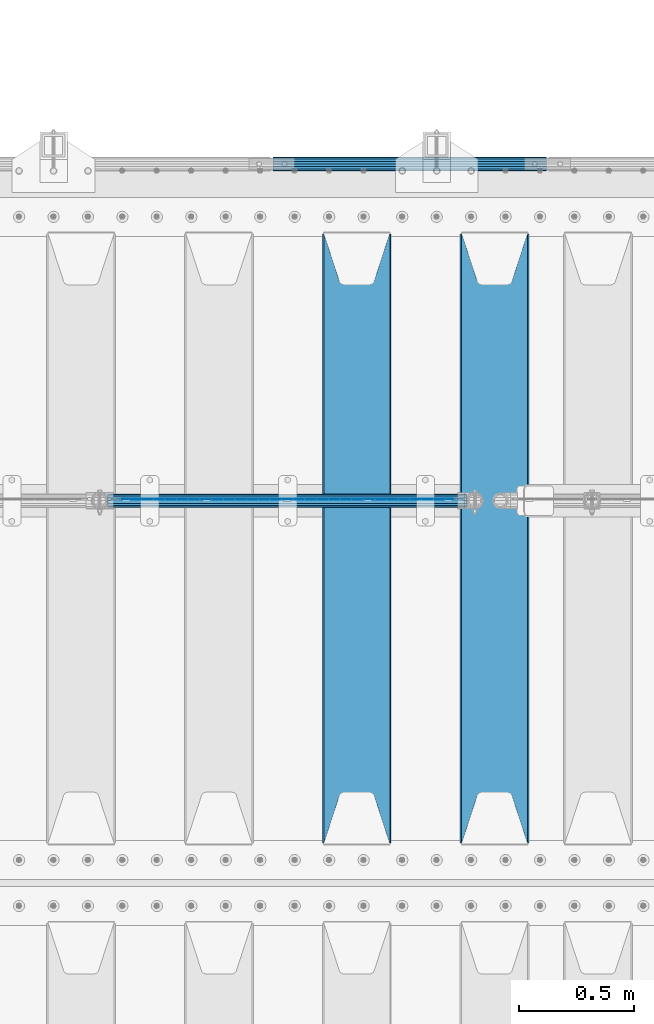
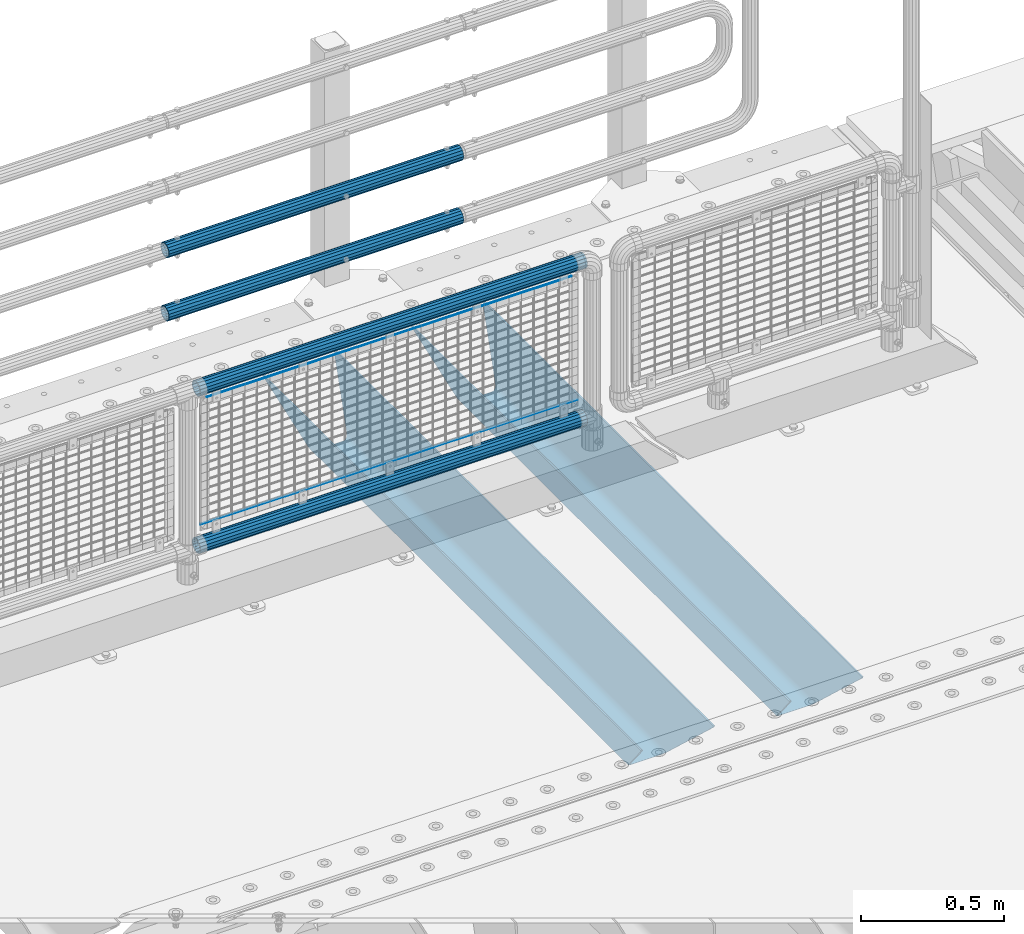
# One storey, part 147 of 270: 8 beams.
"""IFC2X3 building model written with IfcOpenShell, lengths in millimetres."""

from ifc_helpers import new_model, si_unit, frame, origin_with_axes, place, context, subcontext, project, spatial, faceted_brep, material, type_object, element, save


model = new_model("IFC2X3")

# Units and contexts
model_context = context("Model", 3, precision=1e-05, world=origin_with_axes())
body_context = subcontext(model_context, "Body", "Model", "MODEL_VIEW")
ifc_project = project(units=[si_unit("LENGTHUNIT", "METRE", prefix="MILLI"), si_unit("AREAUNIT", "SQUARE_METRE"), si_unit("VOLUMEUNIT", "CUBIC_METRE"), si_unit("MASSUNIT", "GRAM", prefix="KILO"), si_unit("TIMEUNIT", "SECOND"), si_unit("PLANEANGLEUNIT", "RADIAN"), si_unit("SOLIDANGLEUNIT", "STERADIAN"), si_unit("THERMODYNAMICTEMPERATUREUNIT", "DEGREE_CELSIUS"), si_unit("LUMINOUSINTENSITYUNIT", "LUMEN")], contexts=[model_context])

# Site, building, storey
site_placement = place(None, origin_with_axes())
site = spatial("IfcSite", under=ifc_project, at=site_placement, CompositionType="ELEMENT")
building_placement = place(site_placement, origin_with_axes())
building = spatial("IfcBuilding", under=site, at=building_placement, Name="Standard", CompositionType="ELEMENT")
storey_placement = place(building_placement, origin_with_axes())
storey = spatial("IfcBuildingStorey", under=building, at=storey_placement, Name="Undefined", CompositionType="ELEMENT", Elevation=0.0)

# Beams
ifc_material_1 = material()
beam_type_1 = type_object("IfcBeamType", PredefinedType="NOTDEFINED")
beam_1_placement = place(storey_placement, frame((17705.0000000001, -14870.1500000004, 419.849999999726), z_axis=(0.0, -1.0, 0.0), x_axis=(1.0, 0.0, 0.0)))
element("IfcBeam", 1, at=beam_1_placement, inside=storey, type_object=beam_type_1, material=ifc_material_1, context=body_context, shape_type="Brep", body=[
    faceted_brep([(0.0, -26.5499999999993, 0.0), (0.0, -24.5290015881747, 10.1602451292931), (1190.0, -24.5290015881747, 10.1602451292929), (1190.0, -26.55, 0.0), (0.0, -18.7736850405036, 18.7736850405028), (1190.0, -18.7736850405028, 18.7736850405036), (0.0, -10.1602451292929, 24.5290015881747), (1190.0, -10.1602451292931, 24.5290015881747), (0.0, 0.0, 26.55), (1190.0, 0.0, 26.5499999999993), (0.0, 10.1602451292929, 24.5290015881747), (1190.0, 10.1602451292932, 24.5290015881747), (0.0, 18.7736850405036, 18.7736850405028), (1190.0, 18.7736850405029, 18.7736850405036), (0.0, 24.5290015881747, 10.1602451292931), (1190.0, 24.5290015881747, 10.1602451292929), (0.0, 26.5499999999993, 0.0), (1190.0, 26.55, 0.0), (0.0, 24.5290015881747, -10.1602451292931), (1190.0, 24.5290015881747, -10.1602451292929), (0.0, 18.7736850405036, -18.7736850405028), (1190.0, 18.7736850405028, -18.7736850405036), (0.0, 10.1602451292929, -24.5290015881747), (1190.0, 10.1602451292931, -24.5290015881747), (0.0, 0.0, -26.55), (1190.0, 0.0, -26.5499999999993), (0.0, -10.1602451292929, -24.5290015881747), (1190.0, -10.1602451292931, -24.5290015881747), (0.0, -18.7736850405036, -18.7736850405028), (1190.0, -18.7736850405028, -18.7736850405036), (0.0, -24.5290015881747, -10.1602451292931), (1190.0, -24.5290015881747, -10.1602451292929), (0.0, -30.1499999999996, 0.0), (0.0, -27.8549679052157, -11.5379054858058), (1190.0, -27.8549679052153, -11.5379054858076), (1190.0, -30.15, 0.0), (0.0, -21.3192694527752, -21.3192694527752), (1190.0, -21.3192694527744, -21.3192694527752), (0.0, -11.5379054858076, -27.8549679052157), (1190.0, -11.5379054858075, -27.8549679052157), (0.0, 0.0, -30.1500000000015), (1190.0, 0.0, -30.1499999999996), (0.0, 11.5379054858076, -27.8549679052157), (1190.0, 11.5379054858075, -27.8549679052157), (0.0, 21.3192694527752, -21.3192694527752), (1190.0, 21.3192694527744, -21.3192694527752), (0.0, 27.8549679052157, -11.5379054858058), (1190.0, 27.8549679052153, -11.5379054858076), (0.0, 30.1499999999996, 0.0), (1190.0, 30.15, 0.0), (0.0, 27.8549679052157, 11.5379054858058), (1190.0, 27.8549679052153, 11.5379054858076), (0.0, 21.3192694527752, 21.3192694527752), (1190.0, 21.3192694527744, 21.3192694527752), (0.0, 11.5379054858076, 27.8549679052157), (1190.0, 11.5379054858075, 27.8549679052157), (0.0, 0.0, 30.1500000000015), (1190.0, 0.0, 30.1499999999996), (0.0, -11.5379054858076, 27.8549679052157), (1190.0, -11.5379054858075, 27.8549679052157), (0.0, -21.3192694527752, 21.3192694527752), (1190.0, -21.3192694527744, 21.3192694527752), (0.0, -27.8549679052157, 11.5379054858058), (1190.0, -27.8549679052153, 11.5379054858076)], [[[0, 1, 2, 3]], [[1, 4, 5, 2]], [[4, 6, 7, 5]], [[6, 8, 9, 7]], [[8, 10, 11, 9]], [[10, 12, 13, 11]], [[12, 14, 15, 13]], [[14, 16, 17, 15]], [[16, 18, 19, 17]], [[18, 20, 21, 19]], [[20, 22, 23, 21]], [[22, 24, 25, 23]], [[24, 26, 27, 25]], [[26, 28, 29, 27]], [[28, 30, 31, 29]], [[30, 0, 3, 31]], [[32, 33, 34, 35]], [[33, 36, 37, 34]], [[36, 38, 39, 37]], [[38, 40, 41, 39]], [[40, 42, 43, 41]], [[42, 44, 45, 43]], [[44, 46, 47, 45]], [[46, 48, 49, 47]], [[48, 50, 51, 49]], [[50, 52, 53, 51]], [[52, 54, 55, 53]], [[54, 56, 57, 55]], [[56, 58, 59, 57]], [[58, 60, 61, 59]], [[60, 62, 63, 61]], [[62, 32, 35, 63]], [[37, 39, 41, 43, 45, 47, 49, 51, 53, 55, 57, 59, 61, 63, 35, 34], [5, 7, 9, 11, 13, 15, 17, 19, 21, 23, 25, 27, 29, 31, 3, 2]], [[62, 60, 58, 56, 54, 52, 50, 48, 46, 44, 42, 40, 38, 36, 33, 32], [30, 28, 26, 24, 22, 20, 18, 16, 14, 12, 10, 8, 6, 4, 1, 0]]]),
])
beam_2_placement = place(storey_placement, frame((17705.0000000001, -14870.1500000004, 149.549999999726), z_axis=(0.0, -1.0, 0.0), x_axis=(1.0, 0.0, 0.0)))
element("IfcBeam", 2, at=beam_2_placement, inside=storey, type_object=beam_type_1, material=ifc_material_1, context=body_context, shape_type="Brep", body=[
    faceted_brep([(0.0, -26.5499999999993, 0.0), (0.0, -24.5290015881747, 10.1602451292931), (1190.0, -24.5290015881747, 10.1602451292929), (1190.0, -26.55, 0.0), (0.0, -18.7736850405036, 18.7736850405028), (1190.0, -18.7736850405028, 18.7736850405036), (0.0, -10.1602451292929, 24.5290015881747), (1190.0, -10.1602451292931, 24.5290015881747), (0.0, 0.0, 26.55), (1190.0, 0.0, 26.5499999999993), (0.0, 10.1602451292929, 24.5290015881747), (1190.0, 10.1602451292932, 24.5290015881747), (0.0, 18.7736850405036, 18.7736850405028), (1190.0, 18.7736850405029, 18.7736850405036), (0.0, 24.5290015881747, 10.1602451292931), (1190.0, 24.5290015881747, 10.1602451292929), (0.0, 26.5499999999993, 0.0), (1190.0, 26.55, 0.0), (0.0, 24.5290015881747, -10.1602451292931), (1190.0, 24.5290015881747, -10.1602451292929), (0.0, 18.7736850405036, -18.7736850405028), (1190.0, 18.7736850405028, -18.7736850405036), (0.0, 10.1602451292929, -24.5290015881747), (1190.0, 10.1602451292931, -24.5290015881747), (0.0, 0.0, -26.55), (1190.0, 0.0, -26.5499999999993), (0.0, -10.1602451292929, -24.5290015881747), (1190.0, -10.1602451292931, -24.5290015881747), (0.0, -18.7736850405036, -18.7736850405028), (1190.0, -18.7736850405028, -18.7736850405036), (0.0, -24.5290015881747, -10.1602451292931), (1190.0, -24.5290015881747, -10.1602451292929), (0.0, -30.1499999999996, 0.0), (0.0, -27.8549679052157, -11.5379054858058), (1190.0, -27.8549679052153, -11.5379054858076), (1190.0, -30.15, 0.0), (0.0, -21.3192694527752, -21.3192694527752), (1190.0, -21.3192694527744, -21.3192694527752), (0.0, -11.5379054858076, -27.8549679052157), (1190.0, -11.5379054858075, -27.8549679052157), (0.0, 0.0, -30.1500000000015), (1190.0, 0.0, -30.1499999999996), (0.0, 11.5379054858076, -27.8549679052157), (1190.0, 11.5379054858075, -27.8549679052157), (0.0, 21.3192694527752, -21.3192694527752), (1190.0, 21.3192694527744, -21.3192694527752), (0.0, 27.8549679052157, -11.5379054858058), (1190.0, 27.8549679052153, -11.5379054858076), (0.0, 30.1499999999996, 0.0), (1190.0, 30.15, 0.0), (0.0, 27.8549679052157, 11.5379054858058), (1190.0, 27.8549679052153, 11.5379054858076), (0.0, 21.3192694527752, 21.3192694527752), (1190.0, 21.3192694527744, 21.3192694527752), (0.0, 11.5379054858076, 27.8549679052157), (1190.0, 11.5379054858075, 27.8549679052157), (0.0, 0.0, 30.1500000000015), (1190.0, 0.0, 30.1499999999996), (0.0, -11.5379054858076, 27.8549679052157), (1190.0, -11.5379054858075, 27.8549679052157), (0.0, -21.3192694527752, 21.3192694527752), (1190.0, -21.3192694527744, 21.3192694527752), (0.0, -27.8549679052157, 11.5379054858058), (1190.0, -27.8549679052153, 11.5379054858076)], [[[0, 1, 2, 3]], [[1, 4, 5, 2]], [[4, 6, 7, 5]], [[6, 8, 9, 7]], [[8, 10, 11, 9]], [[10, 12, 13, 11]], [[12, 14, 15, 13]], [[14, 16, 17, 15]], [[16, 18, 19, 17]], [[18, 20, 21, 19]], [[20, 22, 23, 21]], [[22, 24, 25, 23]], [[24, 26, 27, 25]], [[26, 28, 29, 27]], [[28, 30, 31, 29]], [[30, 0, 3, 31]], [[32, 33, 34, 35]], [[33, 36, 37, 34]], [[36, 38, 39, 37]], [[38, 40, 41, 39]], [[40, 42, 43, 41]], [[42, 44, 45, 43]], [[44, 46, 47, 45]], [[46, 48, 49, 47]], [[48, 50, 51, 49]], [[50, 52, 53, 51]], [[52, 54, 55, 53]], [[54, 56, 57, 55]], [[56, 58, 59, 57]], [[58, 60, 61, 59]], [[60, 62, 63, 61]], [[62, 32, 35, 63]], [[37, 39, 41, 43, 45, 47, 49, 51, 53, 55, 57, 59, 61, 63, 35, 34], [5, 7, 9, 11, 13, 15, 17, 19, 21, 23, 25, 27, 29, 31, 3, 2]], [[62, 60, 58, 56, 54, 52, 50, 48, 46, 44, 42, 40, 38, 36, 33, 32], [30, 28, 26, 24, 22, 20, 18, 16, 14, 12, 10, 8, 6, 4, 1, 0]]]),
])
ifc_material_2 = material(Name="STEEL/S355N")
beam_type_2 = type_object("IfcBeamType", PredefinedType="NOTDEFINED")
beam_3_placement = place(storey_placement, frame((18670.0, -17825.0, -115.0), z_axis=(0.0, 0.0, 1.0), x_axis=(0.0, 1.0, 0.0)))
element("IfcBeam", 3, at=beam_3_placement, inside=storey, type_object=beam_type_2, material=ifc_material_2, context=body_context, shape_type="Brep", body=[
    faceted_brep([(0.0, 150.0, 115.0), (0.0, 143.689999999999, 115.0), (2650.00000000297, 143.689999999999, 115.0), (2650.00000000297, 150.0, 115.0), (2650.00000000297, 142.059565218398, 110.000000003096), (2650.00000000297, 148.3695652184, 110.000000003096), (2441.90079219209, -80.1103600731112, -98.0992078077845), (2437.7588105432, -77.5672621345584, -102.241189456673), (2434.06523489747, -74.4080125315522, -105.934765102404), (2430.9108609509, -70.710272125576, -109.089139048974), (2428.37322971128, -66.5649389910068, -111.626770288588), (2426.51472138055, -62.0739139532889, -113.485278619323), (2425.38102192092, -57.3475956567672, -114.618978078955), (2424.99999999987, -52.5021667386536, -115.0), (2424.99999999987, 52.5021667386536, -115.0), (2425.38102192092, 57.3475956567672, -114.618978078955), (2426.51472138055, 62.0739139532889, -113.485278619323), (2428.37322971128, 66.5649389910068, -111.626770288588), (2430.9108609509, 70.710272125576, -109.089139048974), (2434.06523489747, 74.4080125315522, -105.934765102404), (2437.7588105432, 77.5672621345584, -102.241189456673), (2441.90079219209, 80.1103600731112, -98.0992078077846), (2446.38936140511, 81.9747917625791, -93.6106385947584), (2448.2494850041, 76.2713538057251, -91.7505149957729), (2444.62967112263, 74.76777986261, -95.3703288772456), (2441.28936334126, 72.7168944282894, -98.710636658607), (2438.31067330439, 70.1691124903846, -101.689326695487), (2435.76682334747, 67.1870637758839, -104.233176652398), (2433.72034654133, 63.8440531834895, -106.279653458539), (2432.22154950042, 60.222258798236, -107.778450499454), (2431.30727574265, 56.4107117849089, -108.692724257221), (2430.99999999987, 52.5031078186876, -109.0), (2430.99999999987, -52.5031078186876, -109.0), (2431.30727574265, -56.4107117849089, -108.692724257221), (2432.22154950042, -60.222258798236, -107.778450499454), (2433.72034654133, -63.8440531834895, -106.279653458539), (2435.76682334747, -67.1870637758839, -104.233176652398), (2438.31067330438, -70.1691124903846, -101.689326695487), (2441.28936334126, -72.7168944282894, -98.7106366586071), (2444.62967112263, -74.76777986261, -95.3703288772457), (2448.2494850041, -76.2713538057251, -91.7505149957729), (2650.00000000297, -142.059565218398, 110.000000003096), (2650.00000000297, -148.3695652184, 110.000000003096), (2446.38936140511, -81.9747917625791, -93.6106385947584), (2650.00000000297, -143.689999999999, 115.0), (2650.00000000297, -150.0, 115.0), (0.0, -143.689999999999, 115.0), (0.0, -150.0, 115.0), (0.0, -148.369565218261, 110.000000002672), (203.610638597431, -81.9747917625791, -93.6106385947584), (208.099207810457, -80.1103600731112, -98.0992078077845), (212.241189459342, -77.5672621345584, -102.241189456673), (215.934765105078, -74.4080125315522, -105.934765102404), (219.089139051644, -70.710272125576, -109.089139048974), (221.626770291259, -66.5649389910068, -111.626770288588), (223.485278621993, -62.0739139532889, -113.485278619323), (224.618978081628, -57.3475956567672, -114.618978078955), (225.00000000267, -52.5021667386536, -115.0), (225.00000000267, 52.5021667386536, -115.0), (224.618978081628, 57.3475956567672, -114.618978078955), (223.485278621993, 62.0739139532889, -113.485278619323), (221.626770291259, 66.5649389910068, -111.626770288588), (219.089139051644, 70.710272125576, -109.089139048974), (215.934765105078, 74.4080125315522, -105.934765102404), (212.241189459342, 77.5672621345584, -102.241189456673), (208.099207810457, 80.1103600731112, -98.0992078077846), (203.610638597431, 81.9747917625791, -93.6106385947584), (0.0, 148.369565218261, 110.000000002672), (0.0, 142.05956521826, 110.000000002672), (201.750514998446, 76.2713538057251, -91.7505149957729), (205.370328879915, 74.76777986261, -95.3703288772456), (208.710636661279, 72.7168944282894, -98.710636658607), (211.689326698157, 70.1691124903846, -101.689326695487), (214.233176655071, 67.1870637758839, -104.233176652398), (216.27965346121, 63.8440531834895, -106.279653458539), (217.778450502126, 60.222258798236, -107.778450499454), (218.692724259894, 56.4107117849089, -108.692724257221), (219.00000000267, 52.5031078186876, -109.0), (219.00000000267, -52.5031078186876, -109.0), (218.692724259894, -56.4107117849089, -108.692724257221), (217.778450502123, -60.222258798236, -107.778450499454), (216.27965346121, -63.8440531834895, -106.279653458539), (214.233176655071, -67.1870637758839, -104.233176652398), (211.689326698157, -70.1691124903846, -101.689326695487), (208.710636661279, -72.7168944282894, -98.7106366586071), (205.370328879915, -74.76777986261, -95.3703288772457), (201.750514998446, -76.2713538057251, -91.7505149957729), (0.0, -142.05956521826, 110.000000002672)], [[[0, 1, 2, 3]], [[3, 2, 4, 5]], [[6, 7, 8, 9, 10, 11, 12, 13, 14, 15, 16, 17, 18, 19, 20, 21, 22, 5, 4, 23, 24, 25, 26, 27, 28, 29, 30, 31, 32, 33, 34, 35, 36, 37, 38, 39, 40, 41, 42, 43]], [[44, 45, 42, 41]], [[46, 47, 45, 44]], [[43, 42, 45, 47, 48, 49]], [[6, 43, 49, 50]], [[7, 6, 50, 51]], [[8, 7, 51, 52]], [[9, 8, 52, 53]], [[10, 9, 53, 54]], [[11, 10, 54, 55]], [[12, 11, 55, 56]], [[13, 12, 56, 57]], [[14, 13, 57, 58]], [[15, 14, 58, 59]], [[16, 15, 59, 60]], [[17, 16, 60, 61]], [[18, 17, 61, 62]], [[19, 18, 62, 63]], [[20, 19, 63, 64]], [[21, 20, 64, 65]], [[22, 21, 65, 66]], [[0, 3, 5, 22, 66, 67]], [[1, 0, 67, 68]], [[23, 4, 2, 1, 68, 69]], [[24, 23, 69, 70]], [[25, 24, 70, 71]], [[26, 25, 71, 72]], [[27, 26, 72, 73]], [[28, 27, 73, 74]], [[29, 28, 74, 75]], [[30, 29, 75, 76]], [[31, 30, 76, 77]], [[32, 31, 77, 78]], [[33, 32, 78, 79]], [[34, 33, 79, 80]], [[35, 34, 80, 81]], [[36, 35, 81, 82]], [[37, 36, 82, 83]], [[38, 37, 83, 84]], [[39, 38, 84, 85]], [[40, 39, 85, 86]], [[46, 44, 41, 40, 86, 87]], [[47, 46, 87, 48]], [[86, 85, 84, 83, 82, 81, 80, 79, 78, 77, 76, 75, 74, 73, 72, 71, 70, 69, 68, 67, 66, 65, 64, 63, 62, 61, 60, 59, 58, 57, 56, 55, 54, 53, 52, 51, 50, 49, 48, 87]]]),
])
beam_4_placement = place(storey_placement, frame((18070.0, -17825.0, -115.0), z_axis=(0.0, 0.0, 1.0), x_axis=(0.0, 1.0, 0.0)))
element("IfcBeam", 4, at=beam_4_placement, inside=storey, type_object=beam_type_2, material=ifc_material_2, context=body_context, shape_type="Brep", body=[
    faceted_brep([(0.0, 150.0, 115.0), (0.0, 143.689999999999, 115.0), (2650.00000000297, 143.689999999999, 115.0), (2650.00000000297, 150.0, 115.0), (2650.00000000297, 142.059565218398, 110.000000003096), (2650.00000000297, 148.3695652184, 110.000000003096), (2441.90079219209, -80.1103600731112, -98.0992078077845), (2437.7588105432, -77.5672621345584, -102.241189456673), (2434.06523489747, -74.4080125315522, -105.934765102404), (2430.9108609509, -70.710272125576, -109.089139048974), (2428.37322971128, -66.5649389910068, -111.626770288588), (2426.51472138055, -62.0739139532889, -113.485278619323), (2425.38102192092, -57.3475956567672, -114.618978078955), (2424.99999999987, -52.5021667386536, -115.0), (2424.99999999987, 52.5021667386536, -115.0), (2425.38102192092, 57.3475956567672, -114.618978078955), (2426.51472138055, 62.0739139532889, -113.485278619323), (2428.37322971128, 66.5649389910068, -111.626770288588), (2430.9108609509, 70.710272125576, -109.089139048974), (2434.06523489747, 74.4080125315522, -105.934765102404), (2437.7588105432, 77.5672621345584, -102.241189456673), (2441.90079219209, 80.1103600731112, -98.0992078077846), (2446.38936140511, 81.9747917625791, -93.6106385947584), (2448.2494850041, 76.2713538057251, -91.7505149957729), (2444.62967112263, 74.76777986261, -95.3703288772456), (2441.28936334126, 72.7168944282894, -98.710636658607), (2438.31067330439, 70.1691124903846, -101.689326695487), (2435.76682334747, 67.1870637758839, -104.233176652398), (2433.72034654133, 63.8440531834895, -106.279653458539), (2432.22154950042, 60.222258798236, -107.778450499454), (2431.30727574265, 56.4107117849089, -108.692724257221), (2430.99999999987, 52.5031078186876, -109.0), (2430.99999999987, -52.5031078186876, -109.0), (2431.30727574265, -56.4107117849089, -108.692724257221), (2432.22154950042, -60.222258798236, -107.778450499454), (2433.72034654133, -63.8440531834895, -106.279653458539), (2435.76682334747, -67.1870637758839, -104.233176652398), (2438.31067330438, -70.1691124903846, -101.689326695487), (2441.28936334126, -72.7168944282894, -98.7106366586071), (2444.62967112263, -74.76777986261, -95.3703288772457), (2448.2494850041, -76.2713538057251, -91.7505149957729), (2650.00000000297, -142.059565218398, 110.000000003096), (2650.00000000297, -148.3695652184, 110.000000003096), (2446.38936140511, -81.9747917625791, -93.6106385947584), (2650.00000000297, -143.689999999999, 115.0), (2650.00000000297, -150.0, 115.0), (0.0, -143.689999999999, 115.0), (0.0, -150.0, 115.0), (0.0, -148.369565218261, 110.000000002672), (203.610638597431, -81.9747917625791, -93.6106385947584), (208.099207810457, -80.1103600731112, -98.0992078077845), (212.241189459342, -77.5672621345584, -102.241189456673), (215.934765105078, -74.4080125315522, -105.934765102404), (219.089139051644, -70.710272125576, -109.089139048974), (221.626770291259, -66.5649389910068, -111.626770288588), (223.485278621993, -62.0739139532889, -113.485278619323), (224.618978081628, -57.3475956567672, -114.618978078955), (225.00000000267, -52.5021667386536, -115.0), (225.00000000267, 52.5021667386536, -115.0), (224.618978081628, 57.3475956567672, -114.618978078955), (223.485278621993, 62.0739139532889, -113.485278619323), (221.626770291259, 66.5649389910068, -111.626770288588), (219.089139051644, 70.710272125576, -109.089139048974), (215.934765105078, 74.4080125315522, -105.934765102404), (212.241189459342, 77.5672621345584, -102.241189456673), (208.099207810457, 80.1103600731112, -98.0992078077846), (203.610638597431, 81.9747917625791, -93.6106385947584), (0.0, 148.369565218261, 110.000000002672), (0.0, 142.05956521826, 110.000000002672), (201.750514998446, 76.2713538057251, -91.7505149957729), (205.370328879915, 74.76777986261, -95.3703288772456), (208.710636661279, 72.7168944282894, -98.710636658607), (211.689326698157, 70.1691124903846, -101.689326695487), (214.233176655071, 67.1870637758839, -104.233176652398), (216.27965346121, 63.8440531834895, -106.279653458539), (217.778450502126, 60.222258798236, -107.778450499454), (218.692724259894, 56.4107117849089, -108.692724257221), (219.00000000267, 52.5031078186876, -109.0), (219.00000000267, -52.5031078186876, -109.0), (218.692724259894, -56.4107117849089, -108.692724257221), (217.778450502123, -60.222258798236, -107.778450499454), (216.27965346121, -63.8440531834895, -106.279653458539), (214.233176655071, -67.1870637758839, -104.233176652398), (211.689326698157, -70.1691124903846, -101.689326695487), (208.710636661279, -72.7168944282894, -98.7106366586071), (205.370328879915, -74.76777986261, -95.3703288772457), (201.750514998446, -76.2713538057251, -91.7505149957729), (0.0, -142.05956521826, 110.000000002672)], [[[0, 1, 2, 3]], [[3, 2, 4, 5]], [[6, 7, 8, 9, 10, 11, 12, 13, 14, 15, 16, 17, 18, 19, 20, 21, 22, 5, 4, 23, 24, 25, 26, 27, 28, 29, 30, 31, 32, 33, 34, 35, 36, 37, 38, 39, 40, 41, 42, 43]], [[44, 45, 42, 41]], [[46, 47, 45, 44]], [[43, 42, 45, 47, 48, 49]], [[6, 43, 49, 50]], [[7, 6, 50, 51]], [[8, 7, 51, 52]], [[9, 8, 52, 53]], [[10, 9, 53, 54]], [[11, 10, 54, 55]], [[12, 11, 55, 56]], [[13, 12, 56, 57]], [[14, 13, 57, 58]], [[15, 14, 58, 59]], [[16, 15, 59, 60]], [[17, 16, 60, 61]], [[18, 17, 61, 62]], [[19, 18, 62, 63]], [[20, 19, 63, 64]], [[21, 20, 64, 65]], [[22, 21, 65, 66]], [[0, 3, 5, 22, 66, 67]], [[1, 0, 67, 68]], [[23, 4, 2, 1, 68, 69]], [[24, 23, 69, 70]], [[25, 24, 70, 71]], [[26, 25, 71, 72]], [[27, 26, 72, 73]], [[28, 27, 73, 74]], [[29, 28, 74, 75]], [[30, 29, 75, 76]], [[31, 30, 76, 77]], [[32, 31, 77, 78]], [[33, 32, 78, 79]], [[34, 33, 79, 80]], [[35, 34, 80, 81]], [[36, 35, 81, 82]], [[37, 36, 82, 83]], [[38, 37, 83, 84]], [[39, 38, 84, 85]], [[40, 39, 85, 86]], [[46, 44, 41, 40, 86, 87]], [[47, 46, 87, 48]], [[86, 85, 84, 83, 82, 81, 80, 79, 78, 77, 76, 75, 74, 73, 72, 71, 70, 69, 68, 67, 66, 65, 64, 63, 62, 61, 60, 59, 58, 57, 56, 55, 54, 53, 52, 51, 50, 49, 48, 87]]]),
])
ifc_material_3 = material(Name="Misc_Undefined")
beam_type_3 = type_object("IfcBeamType", Name="D3", PredefinedType="NOTDEFINED")
beam_5_placement = place(storey_placement, frame((17006.0, -16329.5, 378.02), z_axis=(0.0, 0.0, 1.0), x_axis=(1.0, 0.0, 0.0)))
element("IfcBeam", 5, at=beam_5_placement, inside=storey, type_object=beam_type_3, material=ifc_material_3, ObjectType="D3", context=body_context, shape_type="Brep", body=[
    faceted_brep([(0.0, -1.5, 0.0), (0.0, -0.75, -1.29903810567669), (1523.0, -0.75, -1.29903810567669), (1523.0, -1.5, 0.0), (0.0, 0.75, -1.29903810567669), (1523.0, 0.75, -1.29903810567669), (0.0, 1.5, 0.0), (1523.0, 1.5, 0.0), (0.0, 0.75, 1.29903810567669), (1523.0, 0.75, 1.29903810567669), (0.0, -0.75, 1.29903810567669), (1523.0, -0.75, 1.29903810567669)], [[[0, 1, 2, 3]], [[1, 4, 5, 2]], [[4, 6, 7, 5]], [[6, 8, 9, 7]], [[8, 10, 11, 9]], [[10, 0, 3, 11]], [[5, 7, 9, 11, 3, 2]], [[10, 8, 6, 4, 1, 0]]]),
])
beam_6_placement = place(storey_placement, frame((17031.0, -16329.5, 913.02), z_axis=(0.0, 0.0, 1.0), x_axis=(1.0, 0.0, 0.0)))
element("IfcBeam", 6, at=beam_6_placement, inside=storey, type_object=beam_type_3, material=ifc_material_3, ObjectType="D3", context=body_context, shape_type="Brep", body=[
    faceted_brep([(0.0, -1.5, 0.0), (0.0, -0.75, -1.29903810567669), (1473.0, -0.75, -1.29903810567669), (1473.0, -1.5, 0.0), (0.0, 0.75, -1.29903810567669), (1473.0, 0.75, -1.29903810567663), (0.0, 1.5, 0.0), (1473.0, 1.5, 0.0), (0.0, 0.75, 1.29903810567669), (1473.0, 0.75, 1.29903810567669), (0.0, -0.75, 1.29903810567669), (1473.0, -0.75, 1.29903810567669)], [[[0, 1, 2, 3]], [[1, 4, 5, 2]], [[4, 6, 7, 5]], [[6, 8, 9, 7]], [[8, 10, 11, 9]], [[10, 0, 3, 11]], [[5, 7, 9, 11, 3, 2]], [[10, 8, 6, 4, 1, 0]]]),
])
beam_type_4 = type_object("IfcBeamType", PredefinedType="NOTDEFINED")
beam_7_placement = place(storey_placement, frame((16985.85, -16335.5, 969.849999999999), z_axis=(0.0, 0.0, 1.0), x_axis=(1.0, 0.0, 0.0)))
element("IfcBeam", 7, at=beam_7_placement, inside=storey, type_object=beam_type_4, material=ifc_material_1, context=body_context, shape_type="Brep", body=[
    faceted_brep([(0.0, -25.3500000000004, 0.0), (0.0, -23.4203461491616, 9.70102501045403), (1563.0, -23.4203461491616, 9.70102501045506), (1563.0, -25.3500000000004, 0.0), (0.0, -17.9251569030785, 17.9251569030785), (1563.0, -17.9251569030785, 17.925156903079), (0.0, -9.70102501045585, 23.4203461491597), (1563.0, -9.70102501045585, 23.4203461491611), (0.0, 0.0, 25.3499999999985), (1563.0, 0.0, 25.35), (0.0, 9.70102501045585, 23.4203461491597), (1563.0, 9.70102501045585, 23.4203461491611), (0.0, 17.9251569030785, 17.9251569030785), (1563.0, 17.9251569030785, 17.925156903079), (0.0, 23.4203461491616, 9.70102501045403), (1563.0, 23.4203461491616, 9.70102501045506), (0.0, 25.3500000000004, 0.0), (1563.0, 25.3500000000004, 0.0), (0.0, 23.4203461491616, -9.70102501045403), (1563.0, 23.4203461491616, -9.70102501045506), (0.0, 17.9251569030785, -17.9251569030785), (1563.0, 17.9251569030785, -17.925156903079), (0.0, 9.70102501045585, -23.4203461491597), (1563.0, 9.70102501045585, -23.4203461491611), (0.0, 0.0, -25.3499999999985), (1563.0, 0.0, -25.35), (0.0, -9.70102501045585, -23.4203461491597), (1563.0, -9.70102501045585, -23.4203461491611), (0.0, -17.9251569030785, -17.9251569030785), (1563.0, -17.9251569030785, -17.925156903079), (0.0, -23.4203461491616, -9.70102501045403), (1563.0, -23.4203461491616, -9.70102501045506), (0.0, -30.1499999999996, 0.0), (0.0, -27.8549679052157, -11.5379054858058), (1563.0, -27.8549679052157, -11.5379054858075), (1563.0, -30.1499999999996, 0.0), (0.0, -21.3192694527752, -21.3192694527752), (1563.0, -21.3192694527752, -21.3192694527744), (0.0, -11.5379054858076, -27.8549679052157), (1563.0, -11.5379054858076, -27.8549679052153), (0.0, 0.0, -30.1500000000015), (1563.0, 0.0, -30.15), (0.0, 11.5379054858076, -27.8549679052157), (1563.0, 11.5379054858076, -27.8549679052153), (0.0, 21.3192694527752, -21.3192694527752), (1563.0, 21.3192694527752, -21.3192694527744), (0.0, 27.8549679052157, -11.5379054858058), (1563.0, 27.8549679052157, -11.5379054858074), (0.0, 30.1499999999996, 0.0), (1563.0, 30.1499999999996, 0.0), (0.0, 27.8549679052157, 11.5379054858058), (1563.0, 27.8549679052157, 11.5379054858074), (0.0, 21.3192694527752, 21.3192694527752), (1563.0, 21.3192694527752, 21.3192694527744), (0.0, 11.5379054858076, 27.8549679052157), (1563.0, 11.5379054858076, 27.8549679052153), (0.0, 0.0, 30.1500000000015), (1563.0, 0.0, 30.15), (0.0, -11.5379054858076, 27.8549679052157), (1563.0, -11.5379054858076, 27.8549679052153), (0.0, -21.3192694527752, 21.3192694527752), (1563.0, -21.3192694527752, 21.3192694527744), (0.0, -27.8549679052157, 11.5379054858058), (1563.0, -27.8549679052157, 11.5379054858074)], [[[0, 1, 2, 3]], [[1, 4, 5, 2]], [[4, 6, 7, 5]], [[6, 8, 9, 7]], [[8, 10, 11, 9]], [[10, 12, 13, 11]], [[12, 14, 15, 13]], [[14, 16, 17, 15]], [[16, 18, 19, 17]], [[18, 20, 21, 19]], [[20, 22, 23, 21]], [[22, 24, 25, 23]], [[24, 26, 27, 25]], [[26, 28, 29, 27]], [[28, 30, 31, 29]], [[30, 0, 3, 31]], [[32, 33, 34, 35]], [[33, 36, 37, 34]], [[36, 38, 39, 37]], [[38, 40, 41, 39]], [[40, 42, 43, 41]], [[42, 44, 45, 43]], [[44, 46, 47, 45]], [[46, 48, 49, 47]], [[48, 50, 51, 49]], [[50, 52, 53, 51]], [[52, 54, 55, 53]], [[54, 56, 57, 55]], [[56, 58, 59, 57]], [[58, 60, 61, 59]], [[60, 62, 63, 61]], [[62, 32, 35, 63]], [[37, 39, 41, 43, 45, 47, 49, 51, 53, 55, 57, 59, 61, 63, 35, 34], [5, 7, 9, 11, 13, 15, 17, 19, 21, 23, 25, 27, 29, 31, 3, 2]], [[62, 60, 58, 56, 54, 52, 50, 48, 46, 44, 42, 40, 38, 36, 33, 32], [30, 28, 26, 24, 22, 20, 18, 16, 14, 12, 10, 8, 6, 4, 1, 0]]]),
])
beam_8_placement = place(storey_placement, frame((16985.85, -16335.5, 298.170000000001), z_axis=(0.0, 0.0, 1.0), x_axis=(1.0, 0.0, 0.0)))
element("IfcBeam", 8, at=beam_8_placement, inside=storey, type_object=beam_type_4, material=ifc_material_1, context=body_context, shape_type="Brep", body=[
    faceted_brep([(0.0, -25.3500000000004, 0.0), (0.0, -23.4203461491616, 9.70102501045403), (1563.0, -23.4203461491616, 9.70102501045506), (1563.0, -25.3500000000004, 0.0), (0.0, -17.9251569030785, 17.9251569030785), (1563.0, -17.9251569030785, 17.925156903079), (0.0, -9.70102501045585, 23.4203461491597), (1563.0, -9.70102501045585, 23.4203461491611), (0.0, 0.0, 25.3499999999985), (1563.0, 0.0, 25.35), (0.0, 9.70102501045585, 23.4203461491597), (1563.0, 9.70102501045585, 23.4203461491611), (0.0, 17.9251569030785, 17.9251569030785), (1563.0, 17.9251569030785, 17.925156903079), (0.0, 23.4203461491616, 9.70102501045403), (1563.0, 23.4203461491616, 9.70102501045506), (0.0, 25.3500000000004, 0.0), (1563.0, 25.3500000000004, 0.0), (0.0, 23.4203461491616, -9.70102501045403), (1563.0, 23.4203461491616, -9.70102501045506), (0.0, 17.9251569030785, -17.9251569030785), (1563.0, 17.9251569030785, -17.925156903079), (0.0, 9.70102501045585, -23.4203461491597), (1563.0, 9.70102501045585, -23.4203461491611), (0.0, 0.0, -25.3499999999985), (1563.0, 0.0, -25.35), (0.0, -9.70102501045585, -23.4203461491597), (1563.0, -9.70102501045585, -23.4203461491611), (0.0, -17.9251569030785, -17.9251569030785), (1563.0, -17.9251569030785, -17.925156903079), (0.0, -23.4203461491616, -9.70102501045403), (1563.0, -23.4203461491616, -9.70102501045506), (0.0, -30.1499999999996, 0.0), (0.0, -27.8549679052157, -11.5379054858058), (1563.0, -27.8549679052157, -11.5379054858075), (1563.0, -30.1499999999996, 0.0), (0.0, -21.3192694527752, -21.3192694527752), (1563.0, -21.3192694527752, -21.3192694527744), (0.0, -11.5379054858076, -27.8549679052157), (1563.0, -11.5379054858076, -27.8549679052153), (0.0, 0.0, -30.1500000000015), (1563.0, 0.0, -30.15), (0.0, 11.5379054858076, -27.8549679052157), (1563.0, 11.5379054858076, -27.8549679052153), (0.0, 21.3192694527752, -21.3192694527752), (1563.0, 21.3192694527752, -21.3192694527744), (0.0, 27.8549679052157, -11.5379054858058), (1563.0, 27.8549679052157, -11.5379054858074), (0.0, 30.1499999999996, 0.0), (1563.0, 30.1499999999996, 0.0), (0.0, 27.8549679052157, 11.5379054858058), (1563.0, 27.8549679052157, 11.5379054858074), (0.0, 21.3192694527752, 21.3192694527752), (1563.0, 21.3192694527752, 21.3192694527744), (0.0, 11.5379054858076, 27.8549679052157), (1563.0, 11.5379054858076, 27.8549679052153), (0.0, 0.0, 30.1500000000015), (1563.0, 0.0, 30.15), (0.0, -11.5379054858076, 27.8549679052157), (1563.0, -11.5379054858076, 27.8549679052153), (0.0, -21.3192694527752, 21.3192694527752), (1563.0, -21.3192694527752, 21.3192694527744), (0.0, -27.8549679052157, 11.5379054858058), (1563.0, -27.8549679052157, 11.5379054858074)], [[[0, 1, 2, 3]], [[1, 4, 5, 2]], [[4, 6, 7, 5]], [[6, 8, 9, 7]], [[8, 10, 11, 9]], [[10, 12, 13, 11]], [[12, 14, 15, 13]], [[14, 16, 17, 15]], [[16, 18, 19, 17]], [[18, 20, 21, 19]], [[20, 22, 23, 21]], [[22, 24, 25, 23]], [[24, 26, 27, 25]], [[26, 28, 29, 27]], [[28, 30, 31, 29]], [[30, 0, 3, 31]], [[32, 33, 34, 35]], [[33, 36, 37, 34]], [[36, 38, 39, 37]], [[38, 40, 41, 39]], [[40, 42, 43, 41]], [[42, 44, 45, 43]], [[44, 46, 47, 45]], [[46, 48, 49, 47]], [[48, 50, 51, 49]], [[50, 52, 53, 51]], [[52, 54, 55, 53]], [[54, 56, 57, 55]], [[56, 58, 59, 57]], [[58, 60, 61, 59]], [[60, 62, 63, 61]], [[62, 32, 35, 63]], [[37, 39, 41, 43, 45, 47, 49, 51, 53, 55, 57, 59, 61, 63, 35, 34], [5, 7, 9, 11, 13, 15, 17, 19, 21, 23, 25, 27, 29, 31, 3, 2]], [[62, 60, 58, 56, 54, 52, 50, 48, 46, 44, 42, 40, 38, 36, 33, 32], [30, 28, 26, 24, 22, 20, 18, 16, 14, 12, 10, 8, 6, 4, 1, 0]]]),
])

save(model, "model.ifc")
